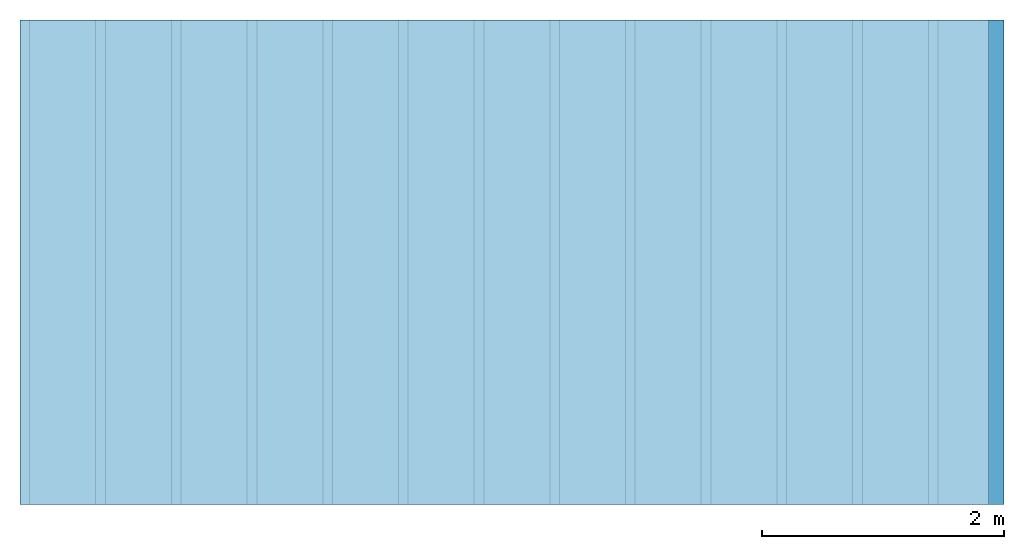
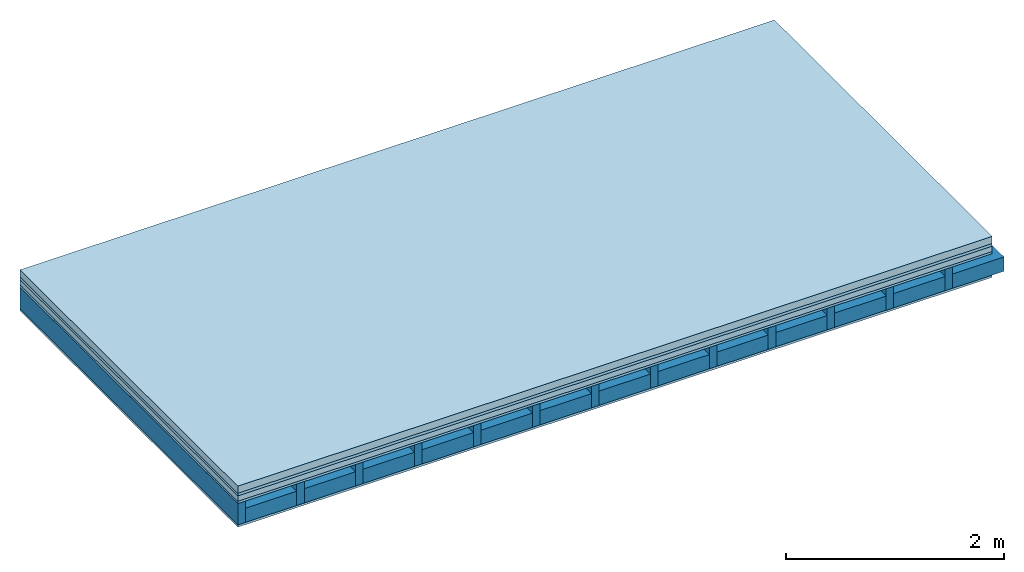
# One storey: 5 plates, 2 members, 1 element without a shape of its own.
"""IFC4 building model written with IfcOpenShell, lengths in metres."""

import ifcopenshell
import ifcopenshell.guid

model = None  # the IFC model being written
_history = None  # IfcOwnerHistory: only IFC2X3 demands one
_inside = {}  # id of a spatial element -> (the spatial element, [elements in it])
_under = {}  # id of a project, library or spatial element -> (it, [spatial elements below it])
_declared = {}  # id of a project -> (the project, [libraries it declares])
_typed = {}  # id of a type object -> (the type object, [elements of that type])
_made_of = {}  # id of a material, layer set ... -> (it, [elements and type objects made of it])


def new_model(schema):
    """Start an empty IFC model of exactly this schema.

    Asked for "IFC4X3", IfcOpenShell would pick the latest addendum, in which some entities
    have other attributes; the version numbers below select the first issue.
    IFC2X3 requires an IfcOwnerHistory on every rooted entity: one is made here for all.
    """
    global model, _history
    if schema == "IFC4X3":
        model = ifcopenshell.file(schema_version=(4, 3, 0, 0))
    else:
        model = ifcopenshell.file(schema=schema)
    _inside.clear()
    _under.clear()
    _declared.clear()
    _typed.clear()
    _made_of.clear()
    _history = None
    if model.schema == "IFC2X3":
        org = make("IfcOrganization", Name="unknown")
        user = make(
            "IfcPersonAndOrganization",
            ThePerson=make("IfcPerson", FamilyName="unknown"),
            TheOrganization=org,
        )
        app = make(
            "IfcApplication",
            ApplicationDeveloper=org,
            Version="unknown",
            ApplicationFullName="unknown",
            ApplicationIdentifier="unknown",
        )
        _history = make(
            "IfcOwnerHistory",
            OwningUser=user,
            OwningApplication=app,
            ChangeAction="ADDED",
            CreationDate=0,
        )
    return model


def make(cls, **values):
    """One entity of the class cls with the attributes given. An attribute that is None is left unset."""
    return model.create_entity(
        cls, **{name: value for name, value in values.items() if value is not None}
    )


def rooted(cls, **values):
    """An entity with a GlobalId (a new one), such as an element, a storey or a relation."""
    return make(cls, GlobalId=ifcopenshell.guid.new(), OwnerHistory=_history, **values)


def si_unit(unit_type, name, prefix=None):
    """IfcSIUnit, for example si_unit("LENGTHUNIT", "METRE", prefix="MILLI")."""
    return make("IfcSIUnit", UnitType=unit_type, Prefix=prefix, Name=name)


def derived_unit(unit_type, elements):
    """IfcDerivedUnit: a product of units, each with its exponent."""
    return make(
        "IfcDerivedUnit",
        Elements=[
            make("IfcDerivedUnitElement", Unit=unit, Exponent=power)
            for unit, power in elements
        ],
        UnitType=unit_type,
    )


def assignment(units):
    """IfcUnitAssignment: the units of a project."""
    return None if units is None else make("IfcUnitAssignment", Units=units)


def point(xyz):
    """IfcCartesianPoint."""
    return None if xyz is None else make("IfcCartesianPoint", Coordinates=xyz)


def direction(xyz):
    """IfcDirection."""
    return None if xyz is None else make("IfcDirection", DirectionRatios=xyz)


def frame(location, z_axis=None, x_axis=None):
    """IfcAxis2Placement3D, a coordinate frame: its origin and axes. An axis left out is left unset."""
    return make(
        "IfcAxis2Placement3D",
        Location=point(location),
        Axis=direction(z_axis),
        RefDirection=direction(x_axis),
    )


def frame_2d(location, x_axis=None):
    """IfcAxis2Placement2D, a coordinate frame in the plane: its origin and x axis."""
    return make(
        "IfcAxis2Placement2D", Location=point(location), RefDirection=direction(x_axis)
    )


def origin():
    """The frame at (0, 0, 0) with its axes left unset."""
    return frame((0.0, 0.0, 0.0))


def origin_with_axes():
    """The frame at (0, 0, 0) with the z axis (0, 0, 1) and the x axis (1, 0, 0) written out."""
    return frame((0.0, 0.0, 0.0), z_axis=(0.0, 0.0, 1.0), x_axis=(1.0, 0.0, 0.0))


def place(relative_to, where):
    """IfcLocalPlacement: puts the frame where relative to a parent placement (None: the world)."""
    return make(
        "IfcLocalPlacement", PlacementRelTo=relative_to, RelativePlacement=where
    )


def context(
    kind, dimensions, precision=None, world=None, true_north=None, identifier=None
):
    """IfcGeometricRepresentationContext, for example the 3D "Model" context."""
    return make(
        "IfcGeometricRepresentationContext",
        ContextIdentifier=identifier,
        ContextType=kind,
        CoordinateSpaceDimension=dimensions,
        Precision=precision,
        WorldCoordinateSystem=world,
        TrueNorth=true_north,
    )


def project(units=None, contexts=None):
    """IfcProject with its units and contexts."""
    return rooted(
        "IfcProject",
        Name="project",
        RepresentationContexts=contexts,
        UnitsInContext=assignment(units),
    )


def spatial(cls, under=None, at=None, **own):
    """A site, building, storey or space (cls), placed at a placement, below another one or the project."""
    s = rooted(cls, ObjectPlacement=at, **own)
    if under is not None:
        _under.setdefault(under.id(), (under, []))[1].append(s)
    return s


def profile(cls, at=None, kind="AREA", **sizes):
    """A parametric profile (cls). Its sizes go by their IFC names, for example OverallWidth=200.0."""
    return make(cls, ProfileType=kind, Position=at, **sizes)


def rectangle(**sizes):
    """IfcRectangleProfileDef."""
    return profile("IfcRectangleProfileDef", **sizes)


def extrude(swept, where, along, depth):
    """IfcExtrudedAreaSolid: the profile swept, set in the frame where, extruded along a direction by depth."""
    return make(
        "IfcExtrudedAreaSolid",
        SweptArea=swept,
        Position=where,
        ExtrudedDirection=direction(along),
        Depth=depth,
    )


def shape(context_of_items, identifier, shape_type, items):
    """IfcShapeRepresentation: the items that make up one representation, for example the "Body"."""
    return make(
        "IfcShapeRepresentation",
        ContextOfItems=context_of_items,
        RepresentationIdentifier=identifier,
        RepresentationType=shape_type,
        Items=items,
    )


def material(Name=None, Category=None):
    """IfcMaterial."""
    return make("IfcMaterial", Name=Name, Category=Category)


def layer(
    of_material, thickness, ventilated=None, Name=None, Category=None, Priority=None
):
    """IfcMaterialLayer: one layer of a wall or slab, of a material (None: an air gap)."""
    return make(
        "IfcMaterialLayer",
        Material=of_material,
        LayerThickness=thickness,
        IsVentilated=ventilated,
        Name=Name,
        Category=Category,
        Priority=Priority,
    )


def layer_set(layers, Name=None):
    """IfcMaterialLayerSet."""
    return make("IfcMaterialLayerSet", MaterialLayers=layers, LayerSetName=Name)


def made_of(thing, what):
    """Note that an element or type object is made of a material, layer set ...; save() writes the relation."""
    if what is not None:
        _made_of.setdefault(what.id(), (what, []))[1].append(thing)
    return thing


def type_object(cls, material=None, **own):
    """A type object (cls), such as IfcWallType, which elements share."""
    return made_of(rooted(cls, **own), material)


def element(
    cls,
    number,
    at=None,
    inside=None,
    cuts=None,
    type_object=None,
    material=None,
    context=None,
    identifier="Body",
    shape_type=None,
    held_by="IfcProductDefinitionShape",
    body=None,
    shapes=None,
    **own,
):
    """One element of the class cls, such as IfcWall. Its Tag is "e" and its number.

    at: its placement. inside: the storey or other place that contains it. cuts: it is an
    opening in that element (IfcRelVoidsElement). A single representation is given by context,
    identifier, shape_type and body (its items); several are given by shapes. held_by: the class
    of the entity that holds the representations. save() writes the other relations.
    """
    e = rooted(cls, Tag="e%d" % number, ObjectPlacement=at, **own)
    if body is not None:
        shapes = [shape(context, identifier, shape_type, body)]
    if shapes is not None:
        e.Representation = make(held_by, Representations=shapes)
    if inside is not None:
        _inside.setdefault(inside.id(), (inside, []))[1].append(e)
    if cuts is not None:
        rooted(
            "IfcRelVoidsElement", RelatingBuildingElement=cuts, RelatedOpeningElement=e
        )
    if type_object is not None:
        _typed.setdefault(type_object.id(), (type_object, []))[1].append(e)
    return made_of(e, material)


def aggregate(whole, parts):
    """IfcRelAggregates: a whole, such as a stair, and the parts it consists of."""
    return rooted("IfcRelAggregates", RelatingObject=whole, RelatedObjects=parts)


def save(model, path):
    """Write the relations noted so far, then the file.

    IfcRelAggregates (storeys below a building ...), IfcRelContainedInSpatialStructure (elements
    in a storey), IfcRelDefinesByType, IfcRelAssociatesMaterial and IfcRelDeclares: one each for
    every whole, place, type object, material and project.
    """
    for whole, parts in _under.values():
        aggregate(whole, parts)
    for where, things in _inside.values():
        rooted(
            "IfcRelContainedInSpatialStructure",
            RelatedElements=things,
            RelatingStructure=where,
        )
    for kind, things in _typed.values():
        rooted("IfcRelDefinesByType", RelatedObjects=things, RelatingType=kind)
    for what, things in _made_of.values():
        rooted("IfcRelAssociatesMaterial", RelatedObjects=things, RelatingMaterial=what)
    for by, libraries in _declared.values():
        rooted("IfcRelDeclares", RelatingContext=by, RelatedDefinitions=libraries)
    model.write(path)


model = new_model("IFC4")

# Units and contexts
plan_context = context("Plan", 3, precision=1e-05, world=origin(), true_north=direction((0.0, 1.0)))
model_context = context("Model", 3, precision=1e-05, world=origin(), true_north=direction((0.0, 1.0)))
ifc_project = project(units=[si_unit("LENGTHUNIT", "METRE"), derived_unit("SOUNDPRESSUREUNIT", [(si_unit("PRESSUREUNIT", "PASCAL", prefix="MICRO"), 0)]), si_unit("ENERGYUNIT", "JOULE", prefix="MEGA"), si_unit("MASSUNIT", "GRAM", prefix="KILO"), derived_unit("THERMALTRANSMITTANCEUNIT", [(si_unit("POWERUNIT", "WATT"), 1), (si_unit("AREAUNIT", "SQUARE_METRE"), -1), (si_unit("THERMODYNAMICTEMPERATUREUNIT", "KELVIN"), -1)]), derived_unit("AREADENSITYUNIT", [(si_unit("MASSUNIT", "GRAM", prefix="KILO"), 1), (si_unit("AREAUNIT", "SQUARE_METRE"), -1)]), derived_unit("USERDEFINED", [(si_unit("ENERGYUNIT", "JOULE", prefix="MEGA"), 1), (si_unit("AREAUNIT", "SQUARE_METRE"), -1)])], contexts=[plan_context, model_context])

# Site, building, storey
site = spatial("IfcSite", under=ifc_project)
building_placement = place(None, origin())
building = spatial("IfcBuilding", under=site, at=building_placement)
storey_placement = place(building_placement, origin())
storey = spatial("IfcBuildingStorey", under=building, at=storey_placement)

# Slab, members, plates
ifc_material_1 = material(Name="Cement screed", Category="04.006")
ifc_layer_1 = layer(ifc_material_1, 0.08, Name="On-material")
ifc_material_2 = material()
ifc_layer_2 = layer(ifc_material_2, 0.03, Name="Impact sound insulation")
ifc_material_3 = material(Name="Cement panels, glued on sub-floor", Category="02.007")
ifc_layer_3 = layer(ifc_material_3, 0.06, Name="on Supporting structure")
ifc_material_4 = material(Category="07.001")
ifc_layer_4 = layer(ifc_material_4, 0.025, Name="Sub-floor")
ifc_material_5 = material(Name="Rigid, of the art")
ifc_layer_5 = layer(ifc_material_5, 0.0, Name="Bond")
ifc_layer_6 = layer(None, 0.24, Name="Supporting structure")
ifc_layer_7 = layer(ifc_material_5, 0.0, Name="Bond")
ifc_layer_8 = layer(ifc_material_4, 0.025, Name="Lower layer 1")
ifc_layer_set = layer_set([ifc_layer_1, ifc_layer_2, ifc_layer_3, ifc_layer_4, ifc_layer_5, ifc_layer_6, ifc_layer_7, ifc_layer_8])
slab_type = type_object("IfcSlabType", Name="A0426", PredefinedType="NOTDEFINED", material=ifc_layer_set)
slab_placement = place(None, frame((0.0, 0.0, 0.0), z_axis=(0.0, 0.0, -1.0), x_axis=(1.0, 0.0, 0.0)))
slab = element("IfcSlab", 1, at=slab_placement, inside=storey, type_object=slab_type, material=ifc_layer_set, Name="Slab #1")
ifc_material_6 = material()
member_1_placement = place(slab_placement, origin())
member_1 = element("IfcMember", 2, at=member_1_placement, material=ifc_material_6, Name="Supporting structure", context=plan_context, shape_type="SweptSolid", body=[
    extrude(rectangle(XDim=0.08, YDim=0.24, at=frame_2d((0.04, 0.12), x_axis=(1.0, 0.0))), frame((0.0, 4.0, 0.195), z_axis=(0.0, -1.0, 0.0), x_axis=(1.0, 0.0, 0.0)), (0.0, 0.0, 1.0), 4.0),
    extrude(rectangle(XDim=0.08, YDim=0.24, at=frame_2d((0.04, 0.12), x_axis=(1.0, 0.0))), frame((0.625, 4.0, 0.195), z_axis=(0.0, -1.0, 0.0), x_axis=(1.0, 0.0, 0.0)), (0.0, 0.0, 1.0), 4.0),
    extrude(rectangle(XDim=0.08, YDim=0.24, at=frame_2d((0.04, 0.12), x_axis=(1.0, 0.0))), frame((1.25, 4.0, 0.195), z_axis=(0.0, -1.0, 0.0), x_axis=(1.0, 0.0, 0.0)), (0.0, 0.0, 1.0), 4.0),
    extrude(rectangle(XDim=0.08, YDim=0.24, at=frame_2d((0.04, 0.12), x_axis=(1.0, 0.0))), frame((1.875, 4.0, 0.195), z_axis=(0.0, -1.0, 0.0), x_axis=(1.0, 0.0, 0.0)), (0.0, 0.0, 1.0), 4.0),
    extrude(rectangle(XDim=0.08, YDim=0.24, at=frame_2d((0.04, 0.12), x_axis=(1.0, 0.0))), frame((2.5, 4.0, 0.195), z_axis=(0.0, -1.0, 0.0), x_axis=(1.0, 0.0, 0.0)), (0.0, 0.0, 1.0), 4.0),
    extrude(rectangle(XDim=0.08, YDim=0.24, at=frame_2d((0.04, 0.12), x_axis=(1.0, 0.0))), frame((3.125, 4.0, 0.195), z_axis=(0.0, -1.0, 0.0), x_axis=(1.0, 0.0, 0.0)), (0.0, 0.0, 1.0), 4.0),
    extrude(rectangle(XDim=0.08, YDim=0.24, at=frame_2d((0.04, 0.12), x_axis=(1.0, 0.0))), frame((3.75, 4.0, 0.195), z_axis=(0.0, -1.0, 0.0), x_axis=(1.0, 0.0, 0.0)), (0.0, 0.0, 1.0), 4.0),
    extrude(rectangle(XDim=0.08, YDim=0.24, at=frame_2d((0.04, 0.12), x_axis=(1.0, 0.0))), frame((4.375, 4.0, 0.195), z_axis=(0.0, -1.0, 0.0), x_axis=(1.0, 0.0, 0.0)), (0.0, 0.0, 1.0), 4.0),
    extrude(rectangle(XDim=0.08, YDim=0.24, at=frame_2d((0.04, 0.12), x_axis=(1.0, 0.0))), frame((5.0, 4.0, 0.195), z_axis=(0.0, -1.0, 0.0), x_axis=(1.0, 0.0, 0.0)), (0.0, 0.0, 1.0), 4.0),
    extrude(rectangle(XDim=0.08, YDim=0.24, at=frame_2d((0.04, 0.12), x_axis=(1.0, 0.0))), frame((5.625, 4.0, 0.195), z_axis=(0.0, -1.0, 0.0), x_axis=(1.0, 0.0, 0.0)), (0.0, 0.0, 1.0), 4.0),
    extrude(rectangle(XDim=0.08, YDim=0.24, at=frame_2d((0.04, 0.12), x_axis=(1.0, 0.0))), frame((6.25, 4.0, 0.195), z_axis=(0.0, -1.0, 0.0), x_axis=(1.0, 0.0, 0.0)), (0.0, 0.0, 1.0), 4.0),
    extrude(rectangle(XDim=0.08, YDim=0.24, at=frame_2d((0.04, 0.12), x_axis=(1.0, 0.0))), frame((6.875, 4.0, 0.195), z_axis=(0.0, -1.0, 0.0), x_axis=(1.0, 0.0, 0.0)), (0.0, 0.0, 1.0), 4.0),
    extrude(rectangle(XDim=0.08, YDim=0.24, at=frame_2d((0.04, 0.12), x_axis=(1.0, 0.0))), frame((7.5, 4.0, 0.195), z_axis=(0.0, -1.0, 0.0), x_axis=(1.0, 0.0, 0.0)), (0.0, 0.0, 1.0), 4.0),
])
ifc_material_7 = material()
member_2_placement = place(slab_placement, origin())
member_2 = element("IfcMember", 3, at=member_2_placement, material=ifc_material_7, Name="Cavity", context=plan_context, shape_type="SweptSolid", body=[
    extrude(rectangle(XDim=0.545, YDim=0.16, at=frame_2d((0.2725, 0.08), x_axis=(1.0, 0.0))), frame((0.08, 4.0, 0.275), z_axis=(0.0, -1.0, 0.0), x_axis=(1.0, 0.0, 0.0)), (0.0, 0.0, 1.0), 4.0),
    extrude(rectangle(XDim=0.545, YDim=0.16, at=frame_2d((0.2725, 0.08), x_axis=(1.0, 0.0))), frame((0.705, 4.0, 0.275), z_axis=(0.0, -1.0, 0.0), x_axis=(1.0, 0.0, 0.0)), (0.0, 0.0, 1.0), 4.0),
    extrude(rectangle(XDim=0.545, YDim=0.16, at=frame_2d((0.2725, 0.08), x_axis=(1.0, 0.0))), frame((1.33, 4.0, 0.275), z_axis=(0.0, -1.0, 0.0), x_axis=(1.0, 0.0, 0.0)), (0.0, 0.0, 1.0), 4.0),
    extrude(rectangle(XDim=0.545, YDim=0.16, at=frame_2d((0.2725, 0.08), x_axis=(1.0, 0.0))), frame((1.955, 4.0, 0.275), z_axis=(0.0, -1.0, 0.0), x_axis=(1.0, 0.0, 0.0)), (0.0, 0.0, 1.0), 4.0),
    extrude(rectangle(XDim=0.545, YDim=0.16, at=frame_2d((0.2725, 0.08), x_axis=(1.0, 0.0))), frame((2.58, 4.0, 0.275), z_axis=(0.0, -1.0, 0.0), x_axis=(1.0, 0.0, 0.0)), (0.0, 0.0, 1.0), 4.0),
    extrude(rectangle(XDim=0.545, YDim=0.16, at=frame_2d((0.2725, 0.08), x_axis=(1.0, 0.0))), frame((3.205, 4.0, 0.275), z_axis=(0.0, -1.0, 0.0), x_axis=(1.0, 0.0, 0.0)), (0.0, 0.0, 1.0), 4.0),
    extrude(rectangle(XDim=0.545, YDim=0.16, at=frame_2d((0.2725, 0.08), x_axis=(1.0, 0.0))), frame((3.83, 4.0, 0.275), z_axis=(0.0, -1.0, 0.0), x_axis=(1.0, 0.0, 0.0)), (0.0, 0.0, 1.0), 4.0),
    extrude(rectangle(XDim=0.545, YDim=0.16, at=frame_2d((0.2725, 0.08), x_axis=(1.0, 0.0))), frame((4.455, 4.0, 0.275), z_axis=(0.0, -1.0, 0.0), x_axis=(1.0, 0.0, 0.0)), (0.0, 0.0, 1.0), 4.0),
    extrude(rectangle(XDim=0.545, YDim=0.16, at=frame_2d((0.2725, 0.08), x_axis=(1.0, 0.0))), frame((5.08, 4.0, 0.275), z_axis=(0.0, -1.0, 0.0), x_axis=(1.0, 0.0, 0.0)), (0.0, 0.0, 1.0), 4.0),
    extrude(rectangle(XDim=0.545, YDim=0.16, at=frame_2d((0.2725, 0.08), x_axis=(1.0, 0.0))), frame((5.705, 4.0, 0.275), z_axis=(0.0, -1.0, 0.0), x_axis=(1.0, 0.0, 0.0)), (0.0, 0.0, 1.0), 4.0),
    extrude(rectangle(XDim=0.545, YDim=0.16, at=frame_2d((0.2725, 0.08), x_axis=(1.0, 0.0))), frame((6.33, 4.0, 0.275), z_axis=(0.0, -1.0, 0.0), x_axis=(1.0, 0.0, 0.0)), (0.0, 0.0, 1.0), 4.0),
    extrude(rectangle(XDim=0.545, YDim=0.16, at=frame_2d((0.2725, 0.08), x_axis=(1.0, 0.0))), frame((6.955, 4.0, 0.275), z_axis=(0.0, -1.0, 0.0), x_axis=(1.0, 0.0, 0.0)), (0.0, 0.0, 1.0), 4.0),
    extrude(rectangle(XDim=0.545, YDim=0.16, at=frame_2d((0.2725, 0.08), x_axis=(1.0, 0.0))), frame((7.58, 4.0, 0.275), z_axis=(0.0, -1.0, 0.0), x_axis=(1.0, 0.0, 0.0)), (0.0, 0.0, 1.0), 4.0),
])
plate_1_placement = place(slab_placement, origin())
plate_1 = element("IfcPlate", 4, at=plate_1_placement, material=ifc_material_1, Name="On-material", context=plan_context, shape_type="SweptSolid", body=[
    extrude(rectangle(XDim=8.0, YDim=4.0, at=frame_2d((4.0, 2.0), x_axis=(1.0, 0.0))), origin_with_axes(), (0.0, 0.0, 1.0), 0.08),
])
plate_2_placement = place(slab_placement, origin())
plate_2 = element("IfcPlate", 5, at=plate_2_placement, material=ifc_material_2, Name="Impact sound insulation", context=plan_context, shape_type="SweptSolid", body=[
    extrude(rectangle(XDim=8.0, YDim=4.0, at=frame_2d((4.0, 2.0), x_axis=(1.0, 0.0))), frame((0.0, 0.0, 0.08), z_axis=(0.0, 0.0, 1.0), x_axis=(1.0, 0.0, 0.0)), (0.0, 0.0, 1.0), 0.03),
])
plate_3_placement = place(slab_placement, origin())
plate_3 = element("IfcPlate", 6, at=plate_3_placement, material=ifc_material_3, Name="on Supporting structure", context=plan_context, shape_type="SweptSolid", body=[
    extrude(rectangle(XDim=8.0, YDim=4.0, at=frame_2d((4.0, 2.0), x_axis=(1.0, 0.0))), frame((0.0, 0.0, 0.11), z_axis=(0.0, 0.0, 1.0), x_axis=(1.0, 0.0, 0.0)), (0.0, 0.0, 1.0), 0.06),
])
plate_4_placement = place(slab_placement, origin())
plate_4 = element("IfcPlate", 7, at=plate_4_placement, material=ifc_material_4, Name="Sub-floor", context=plan_context, shape_type="SweptSolid", body=[
    extrude(rectangle(XDim=8.0, YDim=4.0, at=frame_2d((4.0, 2.0), x_axis=(1.0, 0.0))), frame((0.0, 0.0, 0.17), z_axis=(0.0, 0.0, 1.0), x_axis=(1.0, 0.0, 0.0)), (0.0, 0.0, 1.0), 0.025),
])
plate_5_placement = place(slab_placement, origin())
plate_5 = element("IfcPlate", 8, at=plate_5_placement, material=ifc_material_4, Name="Lower layer 1", context=plan_context, shape_type="SweptSolid", body=[
    extrude(rectangle(XDim=8.0, YDim=4.0, at=frame_2d((4.0, 2.0), x_axis=(1.0, 0.0))), frame((0.0, 0.0, 0.435), z_axis=(0.0, 0.0, 1.0), x_axis=(1.0, 0.0, 0.0)), (0.0, 0.0, 1.0), 0.025),
])
aggregate(slab, [plate_1, plate_2, plate_3, plate_4, member_1, member_2, plate_5])

save(model, "model.ifc")
